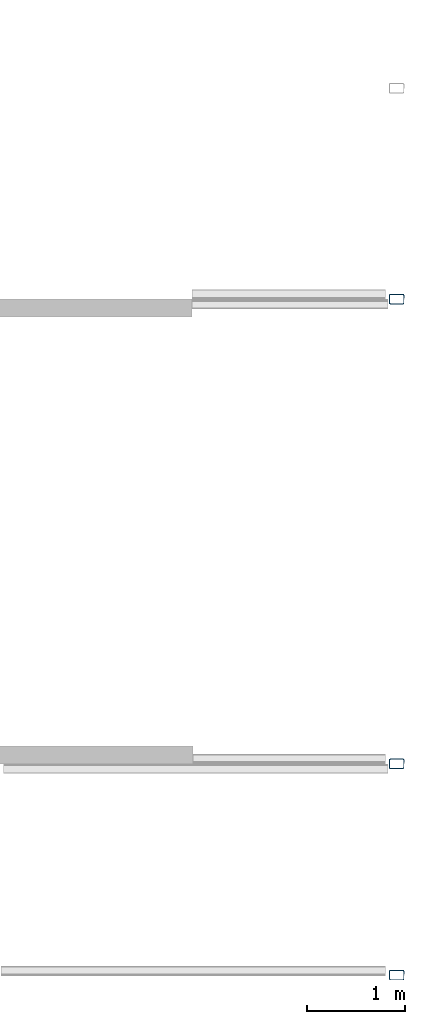
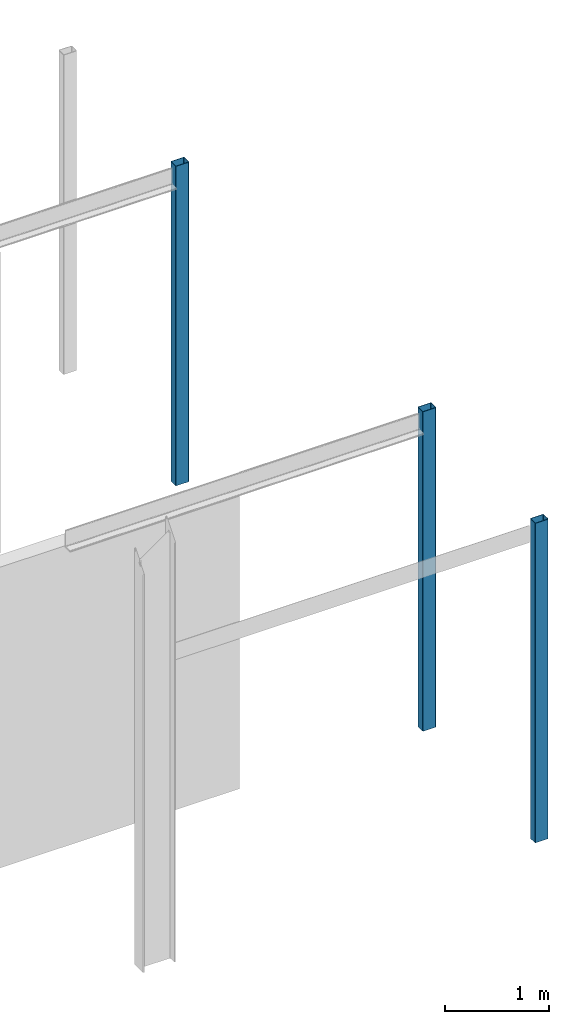
# One storey, part 2 of 4: 3 columns.
"""IFC2X3 building model written with IfcOpenShell, lengths in millimetres."""

from ifc_helpers import new_model, entity, si_unit, converted_unit, frame, frame_2d, origin, place, context, project, spatial, polyline, circle_curve, parameter, trimmed, segment, composite_curve, outline, extrude, source, transform, mapped, material, type_object, type_shapes, element, save


model = new_model("IFC2X3")

# Units and contexts
model_context = context("Model", 3, precision=1e-06, world=origin())
plan_context = context("Plan", 3, precision=1e-06, world=origin())
ifc_project = project(units=[si_unit("LENGTHUNIT", "METRE", prefix="MILLI"), si_unit("AREAUNIT", "SQUARE_METRE", prefix="MILLI"), si_unit("VOLUMEUNIT", "CUBIC_METRE", prefix="MILLI"), converted_unit("PLANEANGLEUNIT", "DEGREE", entity("IfcRatioMeasure", 0.01745329251994328), si_unit("PLANEANGLEUNIT", "RADIAN"), dimensions=[0, 0, 0, 0, 0, 0, 0]), si_unit("TIMEUNIT", "SECOND")], contexts=[model_context, plan_context])

# Site, building, storey
site_placement = place(None, origin())
site = spatial("IfcSite", under=ifc_project, at=site_placement, CompositionType="ELEMENT")
building_placement = place(None, origin())
building = spatial("IfcBuilding", under=site, at=building_placement, CompositionType="ELEMENT")
storey_placement = place(building_placement, origin())
storey = spatial("IfcBuildingStorey", under=building, at=storey_placement, Name="Level 1", CompositionType="ELEMENT", Elevation=0.0)

# Columns
ifc_material = material(Name="Metal - Steel - 345 MPa")
column_type = type_object("IfcColumnType", Name="150x100x5", PredefinedType="COLUMN")
shared_shape = source(origin(), model_context, "Body", "SweptSolid", [
    extrude(outline(composite_curve([segment(polyline([(-40.0, -75.0), (40.0, -75.0)]), True, "CONTINUOUS"), segment(trimmed(circle_curve(frame_2d((40.0, -65.0), x_axis=(-1.0, 0.0)), 9.999999999997998), [parameter(90.00000000000009)], [parameter(180.0000000000002)], True, "PARAMETER"), True, "CONTINUOUS"), segment(polyline([(50.0, -65.0), (50.0, 65.0)]), True, "CONTINUOUS"), segment(trimmed(circle_curve(frame_2d((40.0, 65.0), x_axis=(-1.0, 0.0)), 9.99999999999999), [parameter(179.9999999999999)], [parameter(269.9999999999997)], True, "PARAMETER"), True, "CONTINUOUS"), segment(polyline([(40.0, 75.0), (-40.0, 75.0)]), True, "CONTINUOUS"), segment(trimmed(circle_curve(frame_2d((-40.0, 65.0), x_axis=(-1.0, 0.0)), 10.00000000000288), [parameter(269.9999999999995)], [parameter(359.9999999999996)], True, "PARAMETER"), True, "CONTINUOUS"), segment(polyline([(-50.0, 65.0), (-50.0, -65.0)]), True, "CONTINUOUS"), segment(trimmed(circle_curve(frame_2d((-40.0, -65.0), x_axis=(-1.0, 0.0)), 9.999999999996726), [parameter(359.9999999999996)], [parameter(89.99999999999963)], True, "PARAMETER"), True, "CONTINUOUS")], self_intersect=False), holes=[composite_curve([segment(trimmed(circle_curve(frame_2d((-40.0, -65.0), x_axis=(-1.0, 0.0)), 4.999999999996471), [parameter(0.0)], [parameter(89.99999999999999)], True, "PARAMETER"), False, "CONTINUOUS"), segment(polyline([(-45.0, -65.0), (-45.0, 65.0)]), True, "CONTINUOUS"), segment(trimmed(circle_curve(frame_2d((-40.0, 65.0), x_axis=(-1.0, 0.0)), 4.999999999998176), [parameter(270.0)], [parameter(359.9999999999999)], True, "PARAMETER"), False, "CONTINUOUS"), segment(polyline([(-40.0, 70.0), (40.0, 70.0)]), True, "CONTINUOUS"), segment(trimmed(circle_curve(frame_2d((40.0, 65.0), x_axis=(-1.0, 0.0)), 5.000000000001551), [parameter(180.0000000000001)], [parameter(270.0)], True, "PARAMETER"), False, "CONTINUOUS"), segment(polyline([(45.0, 65.0), (45.0, -65.0)]), True, "CONTINUOUS"), segment(trimmed(circle_curve(frame_2d((40.0, -65.0), x_axis=(-1.0, 0.0)), 5.000000000000011), [parameter(90.0000000000005)], [parameter(179.9999999999998)], True, "PARAMETER"), False, "CONTINUOUS"), segment(polyline([(40.0, -70.0), (-40.0, -70.0)]), True, "CONTINUOUS")], self_intersect=False)]), frame((0.0, 0.0, 0.0), z_axis=(0.0, 0.0, 1.0), x_axis=(-1.0, 0.0, 0.0)), (0.0, 0.0, 1.0), 3750.000000000001),
])
type_shapes(column_type, [shared_shape])
for number, where, z_axis, x_axis in (
    (1, (-11917.18323242557, 151.098768151623, 0.0), (0.0, 0.0, 1.0), (0.0, 1.0, 0.0)),
    (2, (-11917.18323242557, 2311.098768151621, 0.0), (0.0, 0.0, 1.0), (0.0, 1.0, 0.0)),
    (3, (-11917.18323242557, 7061.098768151644, 0.0), (0.0, 0.0, 1.0), (0.0, 1.0, 0.0)),
):
    element("IfcColumn", number, at=place(storey_placement, frame(where, z_axis=z_axis, x_axis=x_axis)), inside=storey, type_object=column_type, material=ifc_material, ObjectType="150x100x5", context=model_context, shape_type="MappedRepresentation", body=[
        mapped(shared_shape, transform((0.0, 0.0, 0.0), scale=1.0)),
    ])

save(model, "model.ifc")
